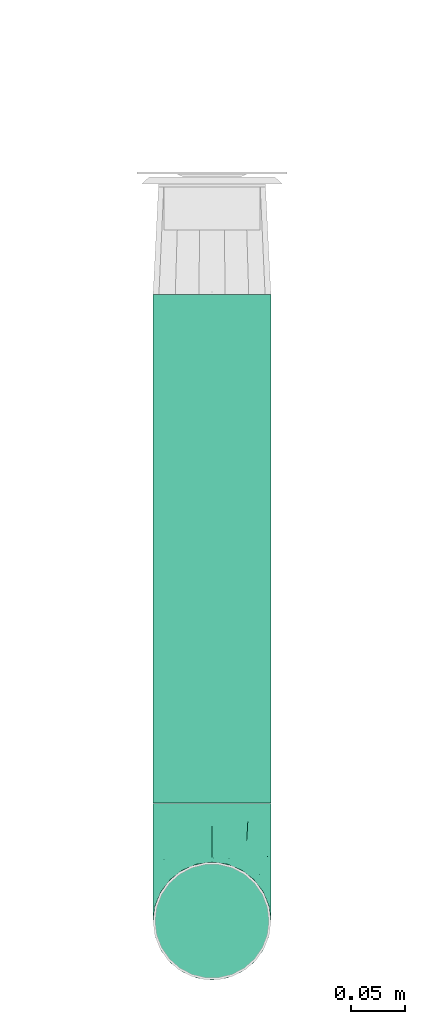
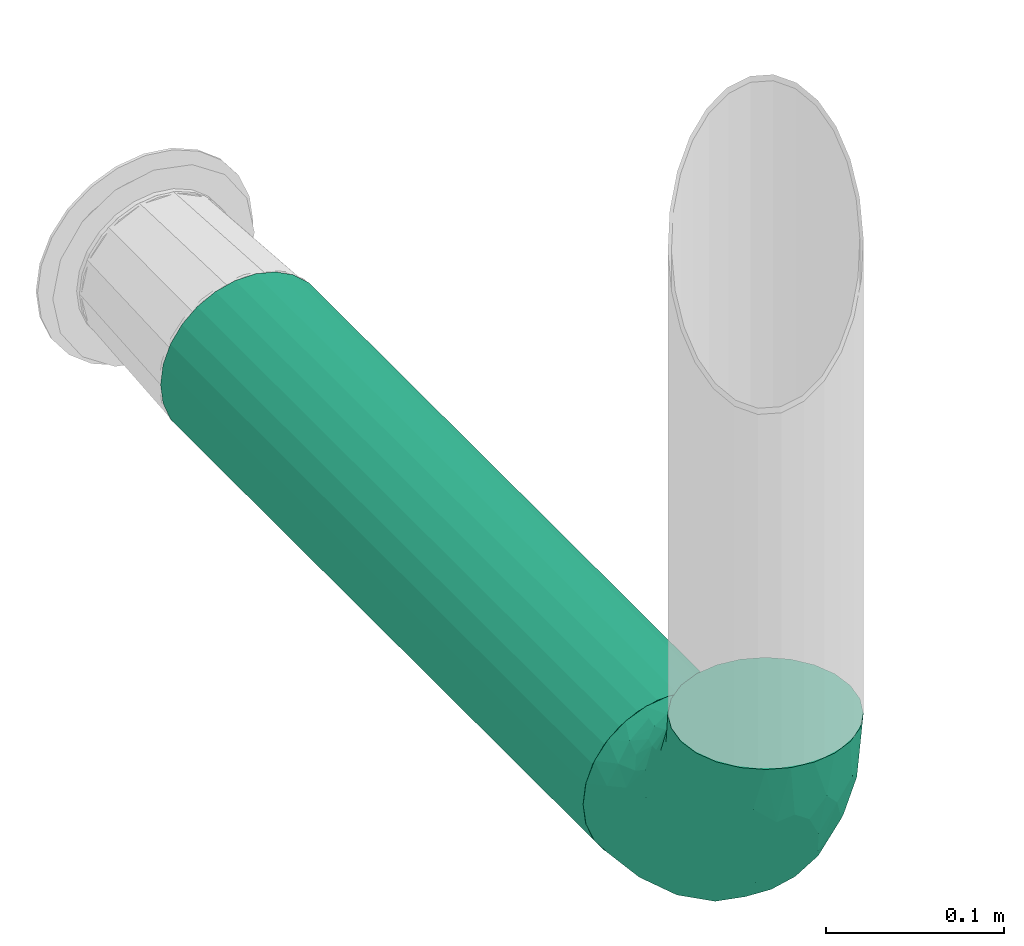
# One storey, part 23 of 123: 1 flow fitting, 1 flow segment.
"""IFC2X3 building model written with IfcOpenShell, lengths in millimetres."""

from ifc_helpers import new_model, entity, si_unit, converted_unit, derived_unit, direction, frame, origin_with_axes, origin_2d_with_axis, place, context, subcontext, project, spatial, hollow_circle, extrude, open_shell, surface_model, source, transform, mapped, material, layer, layer_set, layer_usage, type_object, element, save


model = new_model("IFC2X3")

# Units and contexts
model_context = context("Model", 3, precision=1e-05, world=origin_with_axes(), true_north=direction((0.0, 1.0)))
body_context = subcontext(model_context, "Body", "Model", "MODEL_VIEW")
ifc_project = project(units=[si_unit("AREAUNIT", "SQUARE_METRE"), si_unit("VOLUMEUNIT", "CUBIC_METRE", prefix="DECI"), si_unit("TIMEUNIT", "SECOND"), si_unit("THERMODYNAMICTEMPERATUREUNIT", "DEGREE_CELSIUS"), si_unit("PRESSUREUNIT", "PASCAL"), si_unit("MASSUNIT", "GRAM", prefix="KILO"), si_unit("LENGTHUNIT", "METRE", prefix="MILLI"), si_unit("POWERUNIT", "WATT"), si_unit("ELECTRICCURRENTUNIT", "AMPERE"), si_unit("ELECTRICVOLTAGEUNIT", "VOLT"), derived_unit("VOLUMETRICFLOWRATEUNIT", [(si_unit("VOLUMEUNIT", "CUBIC_METRE", prefix="DECI"), 1), (si_unit("TIMEUNIT", "SECOND"), -1)]), derived_unit("LINEARVELOCITYUNIT", [(si_unit("LENGTHUNIT", "METRE"), 1), (si_unit("TIMEUNIT", "SECOND"), -1)]), derived_unit("MASSDENSITYUNIT", [(si_unit("MASSUNIT", "GRAM", prefix="KILO"), 1), (si_unit("VOLUMEUNIT", "CUBIC_METRE"), -1)]), converted_unit("PLANEANGLEUNIT", "DEGREE", entity("IfcRatioMeasure", 0.01745), si_unit("PLANEANGLEUNIT", "RADIAN"), dimensions=[0, 0, 0, 0, 0, 0, 0])], contexts=[model_context])

# Site, building, storey
site_placement = place(None, origin_with_axes())
site = spatial("IfcSite", under=ifc_project, at=site_placement, CompositionType="ELEMENT")
building_placement = place(site_placement, origin_with_axes())
building = spatial("IfcBuilding", under=site, at=building_placement, Name="mc-building", CompositionType="ELEMENT")
storey_placement = place(building_placement, origin_with_axes())
storey = spatial("IfcBuildingStorey", under=building, at=storey_placement, Name="1. Korrus", CompositionType="ELEMENT", Elevation=0.0)

# Flow fitting
duct_fitting_type = type_object("IfcDuctFittingType", Name="BU", PredefinedType="BEND")
shared_shape_1 = source(origin_with_axes(), body_context, "Body", "SurfaceModel", [
    surface_model("IfcShellBasedSurfaceModel", [(-110.0, -38.89087, -38.89087), (-110.0, -55.0, 0.0), (-110.0, -27.5, -47.63139), (-110.0, -53.12592, -14.23505), (-110.0, -47.63139, -27.5), (-110.0, 47.63139, -27.5), (-110.0, 53.12592, 14.23505), (-110.0, 53.12592, -14.23505), (-110.0, -14.23505, -53.12592), (-110.0, 0.0, -55.0), (-110.0, 38.89087, -38.89087), (-110.0, 27.5, -47.63139), (-110.0, 14.23505, -53.12592), (-110.0, 55.0, 0.0), (-110.0, -53.12592, 14.23505), (-110.0, -47.63139, 27.5), (-110.0, -38.89087, 38.89087), (-110.0, 0.0, 55.0), (-110.0, -27.5, 47.63139), (-110.0, -14.23505, 53.12592), (-110.0, 38.89087, 38.89087), (-110.0, 47.63139, 27.5), (-110.0, 27.5, 47.63139), (-110.0, 14.23505, 53.12592), (0.0, -110.0, -55.0), (14.23505, -110.0, -53.12592), (-14.23505, -110.0, -53.12592), (-53.12592, -110.0, 14.23505), (-27.5, -110.0, -47.63139), (-47.63139, -110.0, -27.5), (-38.89087, -110.0, -38.89087), (55.0, -110.0, 0.0), (53.12592, -110.0, 14.23505), (38.89087, -110.0, -38.89087), (27.5, -110.0, -47.63139), (53.12592, -110.0, -14.23505), (47.63139, -110.0, -27.5), (-53.12592, -110.0, -14.23505), (-47.63139, -110.0, 27.5), (-38.89087, -110.0, 38.89087), (14.23505, -110.0, 53.12592), (-27.5, -110.0, 47.63139), (-14.23505, -110.0, 53.12592), (47.63139, -110.0, 27.5), (38.89087, -110.0, 38.89087), (27.5, -110.0, 47.63139), (0.0, -110.0, 55.0), (-55.0, -110.0, 0.0), (-60.44912, -32.56953, 51.94617), (-76.6405, -38.18013, 45.55988), (-64.21732, -48.68956, 43.63444), (-90.15553, -11.94394, 54.09138), (-76.00813, -5.38378, 55.0), (-70.18771, -18.55163, 54.03432), (-78.5998, -26.77405, 50.81338), (-93.27622, -45.77614, 33.48188), (-75.55424, -54.2118, 32.41257), (-96.12334, -22.13664, 50.81337), (-32.04182, -59.64019, 52.24446), (-18.36258, -70.48427, 54.04484), (-21.00813, -45.34362, 55.0), (-63.60674, -66.07878, 29.97482), (-74.66383, -63.08407, 19.92123), (-63.88653, -74.77858, 17.99134), (-93.11138, -56.59448, 10.50359), (-99.597, -52.72185, 18.52927), (-98.21577, -57.34403, 0.0), (-53.42855, -92.60092, 21.04759), (-88.54852, -54.8376, 21.04759), (-5.38378, -76.00813, 55.0), (-11.86161, -90.23965, 54.10313), (-56.64619, -93.12774, 10.22088), (-57.34403, -98.21577, 0.0), (-44.60838, -44.60838, 52.13415), (-45.34362, -21.00813, 55.0), (-92.68484, -35.46673, 43.63443), (-22.25266, -95.40765, 50.81337), (-27.23711, -77.39884, 50.81337), (-43.70931, -69.58671, 44.47149), (-35.97783, -90.61597, 43.63443), (-58.67786, -84.31125, 16.04456), (-57.2828, -79.3123, 24.9774), (-82.93277, -60.36161, 12.91784), (-49.88337, -54.51816, 47.224), (-74.57753, -66.83759, 9.55742), (-45.35812, -94.97281, 33.48188), (-59.18663, -88.95241, 0.0), (-51.517, -78.6292, 33.48188), (-65.14788, -80.03077, 0.0), (-56.45322, -62.06476, 39.63545), (-88.95241, -59.18663, 0.0), (-80.03077, -65.14788, 0.0), (-71.10913, -71.10913, 0.0), (-94.9309, -45.36788, -33.48188), (-93.11358, -56.60141, -10.46614), (-99.64997, -52.79499, -18.30015), (-79.99933, -46.56772, -37.92748), (-90.20425, -36.08686, -43.63443), (-45.34362, -21.00813, -55.0), (-72.75364, -19.68651, -53.60527), (-76.00813, -5.38378, -55.0), (-21.00813, -45.34362, -55.0), (-5.38378, -76.00813, -55.0), (-21.91957, -65.12078, -53.85897), (-35.41876, -92.89265, -43.63443), (-91.10309, -11.02766, -54.21832), (-45.77614, -93.27622, -33.48188), (-90.50474, -23.21022, -50.81337), (-70.92854, -33.31794, -49.51754), (-78.52933, -63.35627, -11.73997), (-24.91508, -84.05606, -50.81337), (-88.78941, -54.74452, -21.04759), (-63.49062, -67.59111, -28.46929), (-73.36422, -62.46673, -22.94182), (-69.59921, -57.34866, -33.48187), (-56.59448, -93.11138, -10.50359), (-54.10679, -75.85581, -32.31867), (-54.8376, -88.54852, -21.04759), (-57.75956, -31.09612, -52.80882), (-52.72185, -99.597, -18.52927), (-12.62913, -89.46304, -53.99097), (-34.46825, -66.46123, -50.04329), (-43.9837, -43.9837, -52.42279), (-65.78527, -72.58348, -17.68796), (-57.47001, -51.99467, -44.91465), (-70.34468, -43.65295, -44.21951), (-60.72547, -82.29174, -12.88567), (-42.34915, -74.24548, -43.63444), (-57.25194, -63.5016, -38.08211), (-80.95344, -53.56991, -29.32027), (-52.32891, -4.55257, -54.0482), (14.95561, -36.05775, -42.26543), (14.88266, -20.92917, -33.7947), (32.52942, -47.13398, -30.48571), (19.3559, -65.35825, -48.00507), (30.24048, -70.09027, -41.7461), (-28.49299, 30.5778, -16.4009), (-47.13398, 32.52942, -30.48571), (-70.35075, 46.44478, -19.5952), (-22.4954, -22.4954, -53.25347), (-4.55257, -52.32891, -54.0482), (-75.47368, 11.22546, -52.60718), (-81.32209, 51.5606, -9.98467), (-70.09027, 30.24048, -41.7461), (-80.81763, 41.84862, -32.14655), (-9.15831, 10.852, -27.8997), (-36.05774, 14.95561, -42.26543), (-65.35825, 19.3559, -48.00507), (3.94376, -43.9333, -50.53315), (11.22546, -75.47368, -52.60718), (-43.9333, 3.94376, -50.53315), (-13.39742, -13.39743, -48.13058), (50.20582, -74.51695, -9.9731), (41.8609, -47.82256, -9.92641), (49.37776, -67.29486, 0.0), (18.93131, -11.7156, -17.56239), (-1.23348, 12.25375, -12.18106), (-27.5, 32.89419, 0.0), (41.84862, -80.81763, -32.14655), (46.44478, -70.35075, -19.5952), (35.70604, -41.31408, -20.38235), (6.67262, 6.67262, 0.0), (32.89419, -27.5, 0.0), (-50.36265, 42.95545, -9.51562), (-67.29486, 49.37776, 0.0), (-5.47251, -5.47251, -39.92906), (-70.35075, 46.44478, 19.5952), (-74.51695, 50.20582, 9.9731), (-47.13398, 32.52942, 30.48571), (-41.31407, 35.70604, 20.38235), (-80.81763, 41.84862, 32.14655), (11.22546, -75.47368, 52.60718), (-4.55257, -52.32891, 54.0482), (-36.05774, 14.95561, 42.26543), (-65.35825, 19.3559, 48.00507), (-43.9333, 3.94376, 50.53315), (-70.09027, 30.24048, 41.7461), (-11.7156, 18.93131, 17.56239), (12.25375, -1.23348, 12.18106), (30.5778, -28.49299, 16.4009), (42.95545, -50.36265, 9.51562), (51.5606, -81.32209, 9.98467), (-52.32891, -4.55257, 54.0482), (-75.47368, 11.22546, 52.60718), (-13.39742, -13.39743, 48.13058), (-22.4954, -22.4954, 53.25347), (3.94376, -43.9333, 50.53315), (-20.92916, 14.88266, 33.79469), (10.852, -9.15831, 27.8997), (-47.82256, 41.8609, 9.92641), (32.52942, -47.13398, 30.48571), (46.44478, -70.35075, 19.5952), (41.84862, -80.81763, 32.14655), (14.95561, -36.05775, 42.26543), (19.3559, -65.35825, 48.00507), (30.24048, -70.09027, 41.7461), (-5.47251, -5.47251, 39.92906)], [open_shell([[[0, 1, 2]], [[3, 1, 4]], [[5, 6, 7]], [[8, 1, 9]], [[2, 1, 8]], [[4, 1, 0]], [[10, 9, 6]], [[9, 10, 11]], [[11, 12, 9]], [[6, 5, 10]], [[7, 6, 13]], [[14, 15, 9]], [[9, 15, 16]], [[17, 16, 18]], [[9, 16, 17]], [[19, 17, 18]], [[9, 20, 21]], [[6, 9, 21]], [[9, 22, 20]], [[23, 22, 9]], [[17, 23, 9]], [[9, 1, 14]], [[24, 25, 26]], [[26, 27, 28]], [[29, 30, 27]], [[28, 27, 30]], [[26, 31, 32]], [[33, 31, 34]], [[25, 34, 31]], [[35, 31, 36]], [[33, 36, 31]], [[31, 26, 25]], [[29, 27, 37]], [[38, 27, 26]], [[39, 38, 26]], [[40, 41, 26]], [[41, 39, 26]], [[40, 42, 41]], [[43, 44, 26]], [[43, 26, 32]], [[44, 45, 26]], [[26, 45, 40]], [[40, 46, 42]], [[47, 37, 27]], [[48, 49, 50]], [[51, 52, 17]], [[48, 53, 54]], [[49, 55, 56]], [[16, 15, 55]], [[18, 57, 19]], [[58, 59, 60]], [[61, 62, 63]], [[64, 65, 14]], [[53, 51, 54]], [[66, 64, 14]], [[27, 38, 67]], [[65, 68, 55]], [[68, 65, 64]], [[69, 59, 70]], [[71, 72, 27]], [[73, 60, 74]], [[55, 49, 75]], [[42, 70, 76]], [[51, 57, 54]], [[77, 78, 79]], [[42, 76, 41]], [[46, 70, 42]], [[55, 68, 56]], [[75, 18, 16]], [[77, 79, 76]], [[80, 67, 81]], [[68, 82, 62]], [[83, 78, 58]], [[82, 84, 62]], [[39, 79, 85]], [[71, 67, 80]], [[72, 71, 86]], [[67, 85, 87]], [[88, 80, 63]], [[39, 41, 79]], [[87, 79, 78]], [[55, 75, 16]], [[50, 89, 83]], [[38, 39, 85]], [[56, 68, 62]], [[61, 87, 89]], [[48, 50, 83]], [[18, 75, 57]], [[54, 75, 49]], [[38, 85, 67]], [[85, 79, 87]], [[56, 62, 61]], [[50, 56, 89]], [[87, 61, 81]], [[90, 64, 66]], [[14, 1, 66]], [[91, 92, 84]], [[82, 90, 91]], [[90, 82, 64]], [[62, 84, 63]], [[84, 82, 91]], [[64, 82, 68]], [[65, 15, 14]], [[15, 65, 55]], [[72, 47, 27]], [[86, 71, 80]], [[67, 71, 27]], [[88, 63, 92]], [[63, 80, 81]], [[63, 81, 61]], [[87, 81, 67]], [[41, 76, 79]], [[70, 59, 77]], [[76, 70, 77]], [[69, 70, 46]], [[77, 59, 58]], [[59, 69, 60]], [[77, 58, 78]], [[73, 58, 60]], [[19, 57, 51]], [[54, 57, 75]], [[19, 51, 17]], [[53, 52, 51]], [[53, 74, 52]], [[73, 74, 48]], [[53, 48, 74]], [[83, 73, 48]], [[73, 83, 58]], [[78, 83, 89]], [[78, 89, 87]], [[61, 89, 56]], [[54, 49, 48]], [[50, 49, 56]], [[88, 86, 80]], [[63, 84, 92]], [[93, 4, 0]], [[66, 94, 90]], [[95, 94, 3]], [[96, 93, 97]], [[98, 99, 100]], [[0, 2, 97]], [[101, 102, 103]], [[104, 28, 30]], [[9, 105, 8]], [[30, 106, 104]], [[107, 105, 99]], [[97, 107, 108]], [[94, 109, 90]], [[2, 8, 107]], [[94, 66, 3]], [[110, 26, 28]], [[94, 111, 109]], [[112, 113, 114]], [[72, 115, 37]], [[116, 106, 117]], [[98, 118, 99]], [[119, 115, 117]], [[115, 119, 37]], [[110, 120, 26]], [[103, 110, 121]], [[117, 106, 119]], [[120, 110, 103]], [[98, 101, 122]], [[117, 123, 116]], [[108, 124, 125]], [[126, 117, 115]], [[30, 29, 106]], [[120, 102, 24]], [[110, 104, 127]], [[97, 125, 96]], [[118, 122, 124]], [[124, 127, 128]], [[93, 0, 97]], [[86, 126, 115]], [[127, 106, 116]], [[129, 113, 111]], [[4, 93, 95]], [[114, 129, 96]], [[28, 104, 110]], [[127, 104, 106]], [[2, 107, 97]], [[108, 107, 99]], [[118, 108, 99]], [[100, 99, 105]], [[128, 112, 114]], [[127, 124, 121]], [[66, 1, 3]], [[91, 90, 109]], [[95, 111, 94]], [[109, 123, 92]], [[114, 113, 129]], [[111, 95, 93]], [[95, 3, 4]], [[86, 115, 72]], [[37, 47, 72]], [[88, 92, 123]], [[123, 117, 126]], [[126, 88, 123]], [[88, 126, 86]], [[119, 29, 37]], [[29, 119, 106]], [[111, 93, 129]], [[124, 114, 125]], [[100, 105, 9]], [[8, 105, 107]], [[108, 118, 124]], [[122, 118, 98]], [[96, 129, 93]], [[109, 111, 113]], [[113, 123, 109]], [[116, 123, 112]], [[113, 112, 123]], [[116, 112, 128]], [[116, 128, 127]], [[124, 128, 114]], [[103, 122, 101]], [[127, 121, 110]], [[121, 122, 103]], [[122, 121, 124]], [[26, 120, 24]], [[102, 120, 103]], [[108, 125, 97]], [[109, 92, 91]], [[96, 125, 114]], [[100, 130, 98]], [[131, 132, 133]], [[134, 135, 34]], [[136, 137, 138]], [[101, 139, 140]], [[9, 141, 100]], [[138, 7, 142]], [[137, 143, 144]], [[142, 7, 13]], [[145, 146, 137]], [[146, 147, 143]], [[5, 138, 144]], [[7, 138, 5]], [[5, 144, 10]], [[140, 148, 149]], [[143, 11, 10]], [[147, 12, 11]], [[100, 141, 130]], [[98, 139, 101]], [[148, 134, 149]], [[139, 150, 151]], [[152, 153, 154]], [[150, 139, 130]], [[25, 24, 149]], [[141, 12, 147]], [[132, 145, 155]], [[156, 136, 157]], [[158, 33, 135]], [[148, 139, 151]], [[36, 33, 158]], [[34, 135, 33]], [[159, 160, 153]], [[160, 159, 133]], [[137, 146, 143]], [[152, 154, 31]], [[137, 136, 145]], [[161, 162, 155]], [[133, 159, 158]], [[134, 148, 131]], [[163, 164, 157]], [[163, 142, 164]], [[102, 101, 140]], [[162, 154, 153]], [[159, 35, 36]], [[155, 156, 161]], [[131, 165, 132]], [[155, 145, 156]], [[98, 130, 139]], [[150, 130, 141]], [[147, 150, 141]], [[9, 12, 141]], [[149, 24, 102]], [[148, 140, 139]], [[140, 149, 102]], [[34, 25, 134]], [[146, 151, 150]], [[143, 147, 11]], [[147, 146, 150]], [[145, 165, 146]], [[25, 149, 134]], [[135, 134, 131]], [[135, 131, 133]], [[151, 165, 131]], [[148, 151, 131]], [[165, 151, 146]], [[160, 133, 132]], [[132, 165, 145]], [[36, 158, 159]], [[133, 158, 135]], [[10, 144, 143]], [[137, 144, 138]], [[162, 153, 155]], [[159, 153, 152]], [[160, 155, 153]], [[155, 160, 132]], [[152, 35, 159]], [[35, 152, 31]], [[136, 138, 163]], [[164, 142, 13]], [[142, 163, 138]], [[136, 163, 157]], [[161, 156, 157]], [[136, 156, 145]], [[166, 6, 21]], [[167, 164, 13]], [[166, 168, 169]], [[170, 168, 166]], [[69, 171, 172]], [[173, 174, 175]], [[174, 176, 22]], [[161, 157, 177]], [[170, 20, 176]], [[21, 20, 170]], [[178, 179, 162]], [[180, 181, 154]], [[182, 175, 183]], [[183, 23, 17]], [[184, 185, 186]], [[74, 185, 182]], [[52, 74, 182]], [[187, 188, 177]], [[166, 169, 189]], [[190, 179, 188]], [[22, 176, 20]], [[180, 154, 162]], [[32, 191, 43]], [[192, 44, 43]], [[43, 191, 192]], [[32, 31, 181]], [[193, 194, 195]], [[194, 40, 45]], [[190, 193, 195]], [[45, 44, 195]], [[69, 46, 171]], [[74, 60, 185]], [[157, 164, 189]], [[167, 189, 164]], [[172, 60, 69]], [[185, 172, 186]], [[173, 187, 168]], [[191, 32, 181]], [[190, 195, 192]], [[179, 190, 191]], [[175, 174, 183]], [[171, 40, 194]], [[188, 193, 190]], [[175, 185, 184]], [[177, 178, 161]], [[173, 196, 187]], [[177, 188, 178]], [[60, 172, 185]], [[186, 172, 171]], [[194, 186, 171]], [[46, 40, 171]], [[183, 17, 52]], [[175, 182, 185]], [[182, 183, 52]], [[22, 23, 174]], [[193, 184, 186]], [[195, 194, 45]], [[194, 193, 186]], [[188, 196, 193]], [[23, 183, 174]], [[176, 174, 173]], [[176, 173, 168]], [[184, 196, 173]], [[175, 184, 173]], [[196, 184, 193]], [[169, 168, 187]], [[187, 196, 188]], [[21, 170, 166]], [[168, 170, 176]], [[44, 192, 195]], [[190, 192, 191]], [[157, 189, 177]], [[166, 189, 167]], [[169, 177, 189]], [[177, 169, 187]], [[167, 6, 166]], [[6, 167, 13]], [[179, 191, 180]], [[154, 181, 31]], [[181, 180, 191]], [[179, 180, 162]], [[161, 178, 162]], [[179, 178, 188]]])]),
])
flow_fitting_placement = place(storey_placement, frame((5548.85991, -687.64676, 2300.0), z_axis=(1.0, 0.0, 0.0), x_axis=(0.0, -1.0, 0.0)))
element("IfcFlowFitting", 1, at=flow_fitting_placement, inside=storey, type_object=duct_fitting_type, Name="BU", context=body_context, shape_type="MappedRepresentation", body=[
    mapped(shared_shape_1, transform((0.0, 0.0, 0.0), scale=1.0)),
])

# Flow segment
ifc_material = material(Name="FZ1")
ifc_layer = layer(ifc_material, 0.0)
ifc_layer_set = layer_set([ifc_layer], Name="FZ1")
ifc_layer_usage = layer_usage(ifc_layer_set, "AXIS1", "POSITIVE", 0.0)
duct_segment_type = type_object("IfcDuctSegmentType", PredefinedType="RIGIDSEGMENT")
shared_shape_2 = source(origin_with_axes(), body_context, "Body", "SweptSolid", [
    extrude(hollow_circle(Radius=55.0, WallThickness=2.0, at=origin_2d_with_axis()), frame((0.0, 0.0, 0.0), z_axis=(1.0, 0.0, 0.0), x_axis=(0.0, 1.0, 0.0)), (0.0, 0.0, 1.0), 475.2),
])
flow_segment_placement = place(storey_placement, frame((5548.85991, -102.39828, 2300.0), z_axis=(0.0, 0.0, 1.0), x_axis=(0.0, -1.0, 0.0)))
element("IfcFlowSegment", 2, at=flow_segment_placement, inside=storey, type_object=duct_segment_type, material=ifc_layer_usage, context=body_context, shape_type="MappedRepresentation", body=[
    mapped(shared_shape_2, transform((0.0, 0.0, 0.0), scale=1.0)),
])

save(model, "model.ifc")
